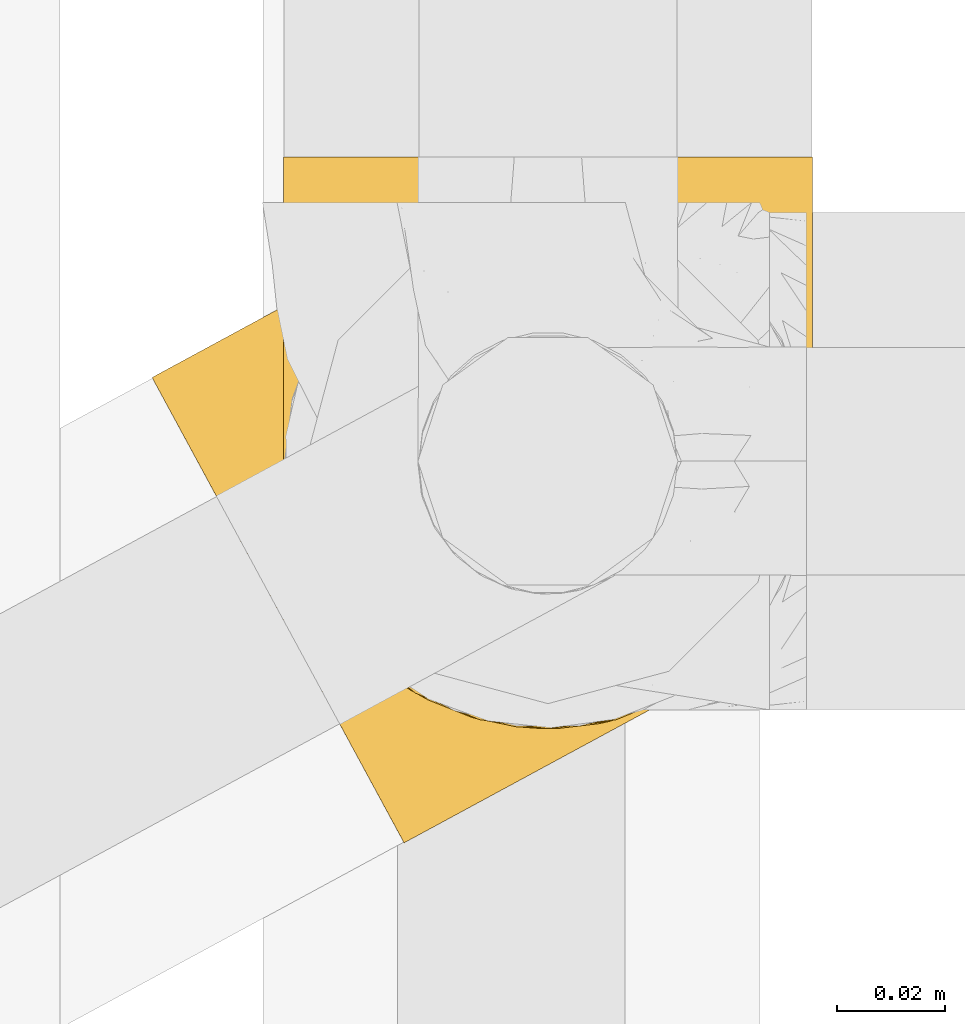
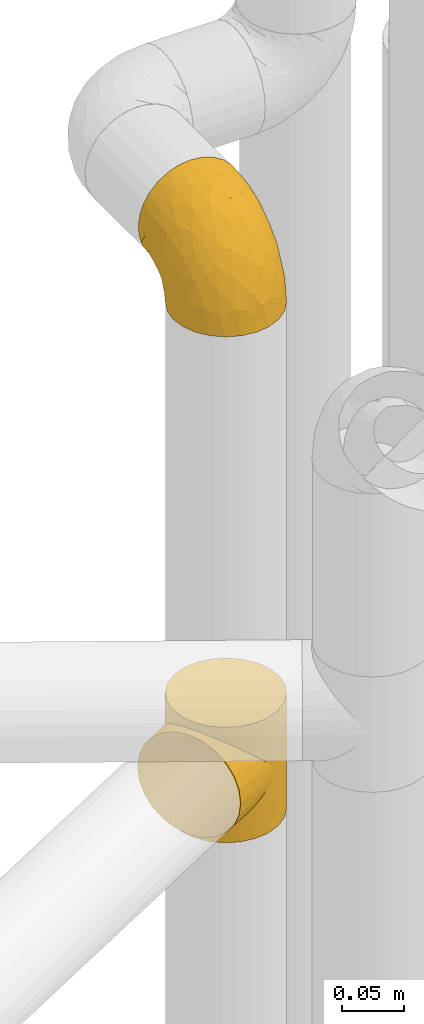
# One storey, part 159 of 827: 2 coverings.
"""IFC2X3 building model written with IfcOpenShell, lengths in millimetres."""

import ifcopenshell
import ifcopenshell.guid

model = None  # the IFC model being written
_history = None  # IfcOwnerHistory: only IFC2X3 demands one
_inside = {}  # id of a spatial element -> (the spatial element, [elements in it])
_under = {}  # id of a project, library or spatial element -> (it, [spatial elements below it])
_declared = {}  # id of a project -> (the project, [libraries it declares])
_typed = {}  # id of a type object -> (the type object, [elements of that type])
_made_of = {}  # id of a material, layer set ... -> (it, [elements and type objects made of it])


def new_model(schema):
    """Start an empty IFC model of exactly this schema.

    Asked for "IFC4X3", IfcOpenShell would pick the latest addendum, in which some entities
    have other attributes; the version numbers below select the first issue.
    IFC2X3 requires an IfcOwnerHistory on every rooted entity: one is made here for all.
    """
    global model, _history
    if schema == "IFC4X3":
        model = ifcopenshell.file(schema_version=(4, 3, 0, 0))
    else:
        model = ifcopenshell.file(schema=schema)
    _inside.clear()
    _under.clear()
    _declared.clear()
    _typed.clear()
    _made_of.clear()
    _history = None
    if model.schema == "IFC2X3":
        org = make("IfcOrganization", Name="unknown")
        user = make(
            "IfcPersonAndOrganization",
            ThePerson=make("IfcPerson", FamilyName="unknown"),
            TheOrganization=org,
        )
        app = make(
            "IfcApplication",
            ApplicationDeveloper=org,
            Version="unknown",
            ApplicationFullName="unknown",
            ApplicationIdentifier="unknown",
        )
        _history = make(
            "IfcOwnerHistory",
            OwningUser=user,
            OwningApplication=app,
            ChangeAction="ADDED",
            CreationDate=0,
        )
    return model


def make(cls, **values):
    """One entity of the class cls with the attributes given. An attribute that is None is left unset."""
    return model.create_entity(
        cls, **{name: value for name, value in values.items() if value is not None}
    )


def entity(cls, *values):
    """Any entity or typed value of the class cls, its attributes in the order of the schema. None: left unset."""
    e = model.create_entity(cls)
    for i, value in enumerate(values):
        if value is not None:
            e[i] = value
    return e


def rooted(cls, **values):
    """An entity with a GlobalId (a new one), such as an element, a storey or a relation."""
    return make(cls, GlobalId=ifcopenshell.guid.new(), OwnerHistory=_history, **values)


def si_unit(unit_type, name, prefix=None):
    """IfcSIUnit, for example si_unit("LENGTHUNIT", "METRE", prefix="MILLI")."""
    return make("IfcSIUnit", UnitType=unit_type, Prefix=prefix, Name=name)


def converted_unit(unit_type, name, factor, base, dimensions=None, offset=None):
    """IfcConversionBasedUnit, such as the inch: factor (a typed value) times the base unit."""
    return make(
        "IfcConversionBasedUnit"
        if offset is None
        else "IfcConversionBasedUnitWithOffset",
        ConversionOffset=offset,
        Dimensions=None
        if dimensions is None
        else entity("IfcDimensionalExponents", *dimensions),
        UnitType=unit_type,
        Name=name,
        ConversionFactor=make(
            "IfcMeasureWithUnit", ValueComponent=factor, UnitComponent=base
        ),
    )


def derived_unit(unit_type, elements):
    """IfcDerivedUnit: a product of units, each with its exponent."""
    return make(
        "IfcDerivedUnit",
        Elements=[
            make("IfcDerivedUnitElement", Unit=unit, Exponent=power)
            for unit, power in elements
        ],
        UnitType=unit_type,
    )


def assignment(units):
    """IfcUnitAssignment: the units of a project."""
    return None if units is None else make("IfcUnitAssignment", Units=units)


def point(xyz):
    """IfcCartesianPoint."""
    return None if xyz is None else make("IfcCartesianPoint", Coordinates=xyz)


def direction(xyz):
    """IfcDirection."""
    return None if xyz is None else make("IfcDirection", DirectionRatios=xyz)


def frame(location, z_axis=None, x_axis=None):
    """IfcAxis2Placement3D, a coordinate frame: its origin and axes. An axis left out is left unset."""
    return make(
        "IfcAxis2Placement3D",
        Location=point(location),
        Axis=direction(z_axis),
        RefDirection=direction(x_axis),
    )


def origin():
    """The frame at (0, 0, 0) with its axes left unset."""
    return frame((0.0, 0.0, 0.0))


def place(relative_to, where):
    """IfcLocalPlacement: puts the frame where relative to a parent placement (None: the world)."""
    return make(
        "IfcLocalPlacement", PlacementRelTo=relative_to, RelativePlacement=where
    )


def context(
    kind, dimensions, precision=None, world=None, true_north=None, identifier=None
):
    """IfcGeometricRepresentationContext, for example the 3D "Model" context."""
    return make(
        "IfcGeometricRepresentationContext",
        ContextIdentifier=identifier,
        ContextType=kind,
        CoordinateSpaceDimension=dimensions,
        Precision=precision,
        WorldCoordinateSystem=world,
        TrueNorth=true_north,
    )


def subcontext(parent, identifier, kind, view, scale=None):
    """IfcGeometricRepresentationSubContext, for example "Body" below "Model"."""
    return make(
        "IfcGeometricRepresentationSubContext",
        ContextIdentifier=identifier,
        ContextType=kind,
        ParentContext=parent,
        TargetScale=scale,
        TargetView=view,
    )


def project(units=None, contexts=None):
    """IfcProject with its units and contexts."""
    return rooted(
        "IfcProject",
        Name="project",
        RepresentationContexts=contexts,
        UnitsInContext=assignment(units),
    )


def spatial(cls, under=None, at=None, **own):
    """A site, building, storey or space (cls), placed at a placement, below another one or the project."""
    s = rooted(cls, ObjectPlacement=at, **own)
    if under is not None:
        _under.setdefault(under.id(), (under, []))[1].append(s)
    return s


def faces_of(points, faces, orient=None, outer=None):
    """IfcFace entities. A face is a list of loops; a loop is a list of indices into points, from 0.

    orient and outer hold one flag for each loop. By default every Orientation is true, the
    first loop of a face is its IfcFaceOuterBound and the others are IfcFaceBound.
    """
    made = []
    for i, loops in enumerate(faces):
        bounds = []
        for j, loop in enumerate(loops):
            is_outer = j == 0 if outer is None else outer[i][j]
            bounds.append(
                make(
                    "IfcFaceOuterBound" if is_outer else "IfcFaceBound",
                    Bound=make("IfcPolyLoop", Polygon=[points[k] for k in loop]),
                    Orientation=True if orient is None else orient[i][j],
                )
            )
        made.append(make("IfcFace", Bounds=bounds))
    return made


def faceted_brep(points, faces, orient=None, outer=None, voids=None):
    """IfcFacetedBrep: a solid bounded by flat faces; with voids (closed shells), ...WithVoids."""
    shared = [point(p) for p in points]
    hull = make("IfcClosedShell", CfsFaces=faces_of(shared, faces, orient, outer))
    if voids is None:
        return make("IfcFacetedBrep", Outer=hull)
    return make(
        "IfcFacetedBrepWithVoids",
        Outer=hull,
        Voids=[
            make(cls, CfsFaces=faces_of(shared, fs, o, b)) for cls, fs, o, b in voids
        ],
    )


def shape(context_of_items, identifier, shape_type, items):
    """IfcShapeRepresentation: the items that make up one representation, for example the "Body"."""
    return make(
        "IfcShapeRepresentation",
        ContextOfItems=context_of_items,
        RepresentationIdentifier=identifier,
        RepresentationType=shape_type,
        Items=items,
    )


def made_of(thing, what):
    """Note that an element or type object is made of a material, layer set ...; save() writes the relation."""
    if what is not None:
        _made_of.setdefault(what.id(), (what, []))[1].append(thing)
    return thing


def element(
    cls,
    number,
    at=None,
    inside=None,
    cuts=None,
    type_object=None,
    material=None,
    context=None,
    identifier="Body",
    shape_type=None,
    held_by="IfcProductDefinitionShape",
    body=None,
    shapes=None,
    **own,
):
    """One element of the class cls, such as IfcWall. Its Tag is "e" and its number.

    at: its placement. inside: the storey or other place that contains it. cuts: it is an
    opening in that element (IfcRelVoidsElement). A single representation is given by context,
    identifier, shape_type and body (its items); several are given by shapes. held_by: the class
    of the entity that holds the representations. save() writes the other relations.
    """
    e = rooted(cls, Tag="e%d" % number, ObjectPlacement=at, **own)
    if body is not None:
        shapes = [shape(context, identifier, shape_type, body)]
    if shapes is not None:
        e.Representation = make(held_by, Representations=shapes)
    if inside is not None:
        _inside.setdefault(inside.id(), (inside, []))[1].append(e)
    if cuts is not None:
        rooted(
            "IfcRelVoidsElement", RelatingBuildingElement=cuts, RelatedOpeningElement=e
        )
    if type_object is not None:
        _typed.setdefault(type_object.id(), (type_object, []))[1].append(e)
    return made_of(e, material)


def aggregate(whole, parts):
    """IfcRelAggregates: a whole, such as a stair, and the parts it consists of."""
    return rooted("IfcRelAggregates", RelatingObject=whole, RelatedObjects=parts)


def save(model, path):
    """Write the relations noted so far, then the file.

    IfcRelAggregates (storeys below a building ...), IfcRelContainedInSpatialStructure (elements
    in a storey), IfcRelDefinesByType, IfcRelAssociatesMaterial and IfcRelDeclares: one each for
    every whole, place, type object, material and project.
    """
    for whole, parts in _under.values():
        aggregate(whole, parts)
    for where, things in _inside.values():
        rooted(
            "IfcRelContainedInSpatialStructure",
            RelatedElements=things,
            RelatingStructure=where,
        )
    for kind, things in _typed.values():
        rooted("IfcRelDefinesByType", RelatedObjects=things, RelatingType=kind)
    for what, things in _made_of.values():
        rooted("IfcRelAssociatesMaterial", RelatedObjects=things, RelatingMaterial=what)
    for by, libraries in _declared.values():
        rooted("IfcRelDeclares", RelatingContext=by, RelatedDefinitions=libraries)
    model.write(path)


model = new_model("IFC2X3")

# Units and contexts
model_context = context("Model", 3, precision=0.01, world=origin(), true_north=direction((6.12303176911189e-17, 1.0)))
body_context = subcontext(model_context, "Body", "Model", "MODEL_VIEW")
ifc_project = project(units=[si_unit("LENGTHUNIT", "METRE", prefix="MILLI"), si_unit("AREAUNIT", "SQUARE_METRE"), si_unit("VOLUMEUNIT", "CUBIC_METRE"), converted_unit("PLANEANGLEUNIT", "DEGREE", entity("IfcRatioMeasure", 0.0174532925199433), si_unit("PLANEANGLEUNIT", "RADIAN"), dimensions=[0, 0, 0, 0, 0, 0, 0]), si_unit("MASSUNIT", "GRAM", prefix="KILO"), derived_unit("MASSDENSITYUNIT", [(si_unit("MASSUNIT", "GRAM", prefix="KILO"), 1), (si_unit("LENGTHUNIT", "METRE"), -3)]), derived_unit("MOMENTOFINERTIAUNIT", [(si_unit("LENGTHUNIT", "METRE"), 4)]), si_unit("TIMEUNIT", "SECOND"), si_unit("FREQUENCYUNIT", "HERTZ"), si_unit("THERMODYNAMICTEMPERATUREUNIT", "DEGREE_CELSIUS"), derived_unit("THERMALTRANSMITTANCEUNIT", [(si_unit("MASSUNIT", "GRAM", prefix="KILO"), 1), (si_unit("THERMODYNAMICTEMPERATUREUNIT", "KELVIN"), -1), (si_unit("TIMEUNIT", "SECOND"), -3)]), derived_unit("VOLUMETRICFLOWRATEUNIT", [(si_unit("LENGTHUNIT", "METRE"), 3), (si_unit("TIMEUNIT", "SECOND"), -1)]), derived_unit("MASSFLOWRATEUNIT", [(si_unit("MASSUNIT", "GRAM", prefix="KILO"), 1), (si_unit("TIMEUNIT", "SECOND"), -1)]), derived_unit("ROTATIONALFREQUENCYUNIT", [(si_unit("TIMEUNIT", "SECOND"), -1)]), si_unit("ELECTRICCURRENTUNIT", "AMPERE"), si_unit("ELECTRICVOLTAGEUNIT", "VOLT"), si_unit("POWERUNIT", "WATT"), si_unit("FORCEUNIT", "NEWTON", prefix="KILO"), si_unit("ILLUMINANCEUNIT", "LUX"), si_unit("LUMINOUSFLUXUNIT", "LUMEN"), si_unit("LUMINOUSINTENSITYUNIT", "CANDELA"), derived_unit("USERDEFINED", [(si_unit("MASSUNIT", "GRAM", prefix="KILO"), -1), (si_unit("LENGTHUNIT", "METRE"), -2), (si_unit("TIMEUNIT", "SECOND"), 3), (si_unit("LUMINOUSFLUXUNIT", "LUMEN"), 1)]), derived_unit("LINEARVELOCITYUNIT", [(si_unit("LENGTHUNIT", "METRE"), 1), (si_unit("TIMEUNIT", "SECOND"), -1)]), si_unit("PRESSUREUNIT", "PASCAL"), derived_unit("USERDEFINED", [(si_unit("LENGTHUNIT", "METRE"), -2), (si_unit("MASSUNIT", "GRAM", prefix="KILO"), 1), (si_unit("TIMEUNIT", "SECOND"), -2)]), derived_unit("LINEARFORCEUNIT", [(si_unit("MASSUNIT", "GRAM", prefix="KILO"), 1), (si_unit("LENGTHUNIT", "METRE"), 1), (si_unit("TIMEUNIT", "SECOND"), -2), (si_unit("LENGTHUNIT", "METRE"), -1)]), derived_unit("PLANARFORCEUNIT", [(si_unit("MASSUNIT", "GRAM", prefix="KILO"), 1), (si_unit("LENGTHUNIT", "METRE"), 1), (si_unit("TIMEUNIT", "SECOND"), -2), (si_unit("LENGTHUNIT", "METRE"), -2)])], contexts=[model_context])

# Site, building, storey
site_placement = place(None, origin())
site = spatial("IfcSite", under=ifc_project, at=site_placement, CompositionType="ELEMENT")
building_placement = place(site_placement, origin())
building = spatial("IfcBuilding", under=site, at=building_placement, CompositionType="ELEMENT")
storey_placement = place(building_placement, frame((0.0, 0.0, 28200.0)))
storey = spatial("IfcBuildingStorey", under=building, at=storey_placement, Name="08", CompositionType="ELEMENT", Elevation=28200.0)

# Coverings
covering_1_placement = place(storey_placement, frame((35661.73, 11733.71, 2043.0)))
element("IfcCovering", 1, at=covering_1_placement, inside=storey, Name=":ADSK_", ObjectType=":ADSK_", PredefinedType="INSULATION", context=body_context, shape_type="Brep", body=[
    faceted_brep([(46.11, 111.63, 50.38), (51.72, 115.18, 0.0), (41.33, 107.65, 0.0), (33.24, 97.68, 0.0), (36.42, 102.26, 37.4), (29.35, 89.87, 25.28), (28.01, 85.97, 0.0), (32.5, 96.44, 31.18), (51.72, 115.18, 57.0), (46.11, 111.63, 63.62), (51.72, 115.18, 114.0), (30.08, 52.85, 8.29), (29.61, 54.55, 0.0), (30.76, 51.55, 0.0), (40.99, 107.32, 43.83), (31.9, 48.55, 7.85), (31.9, 48.55, 0.0), (30.76, 51.55, 114.0), (31.9, 48.55, 106.15), (31.9, 48.55, 114.0), (27.13, 82.55, 19.84), (25.99, 73.3, 0.0), (26.65, 66.92, 0.0), (27.32, 60.54, 0.0), (27.3, 61.56, 10.0), (28.26, 57.15, 8.74), (26.04, 74.54, 15.07), (26.34, 65.98, 11.25), (28.46, 57.54, 0.0), (33.78, 45.96, 0.0), (35.67, 43.36, 0.0), (34.83, 44.29, 8.4), (37.76, 40.02, 8.94), (37.55, 40.76, 0.0), (39.43, 38.16, 0.0), (44.97, 33.14, 12.0), (44.41, 34.12, 0.0), (49.39, 30.08, 0.0), (41.37, 36.58, 10.47), (52.88, 28.13, 16.57), (55.25, 27.46, 0.0), (61.03, 24.87, 22.18), (48.92, 30.64, 14.29), (33.37, 46.42, 8.12), (61.11, 24.85, 0.0), (69.13, 23.17, 28.5), (73.78, 22.83, 0.0), (77.03, 22.84, 35.29), (86.54, 24.15, 0.0), (91.8, 25.72, 49.65), (98.53, 28.74, 0.0), (33.37, 46.42, 105.88), (84.61, 23.73, 42.38), (98.53, 28.74, 57.0), (91.8, 25.72, 64.35), (98.53, 28.74, 114.0), (124.25, 70.62, 114.0), (122.93, 83.38, 114.0), (118.34, 95.36, 114.0), (110.81, 105.75, 114.0), (100.85, 113.84, 114.0), (89.13, 119.07, 114.0), (76.46, 121.09, 114.0), (63.7, 119.76, 114.0), (41.33, 107.65, 114.0), (33.24, 97.68, 114.0), (28.01, 85.97, 114.0), (25.99, 73.3, 114.0), (26.65, 66.92, 114.0), (27.32, 60.54, 114.0), (28.46, 57.54, 114.0), (29.61, 54.55, 114.0), (33.78, 45.96, 114.0), (35.67, 43.36, 114.0), (37.55, 40.76, 114.0), (39.43, 38.16, 114.0), (44.41, 34.12, 114.0), (49.39, 30.08, 114.0), (55.25, 27.46, 114.0), (61.11, 24.85, 114.0), (73.78, 22.83, 114.0), (86.54, 24.15, 114.0), (108.92, 36.27, 114.0), (117.0, 46.23, 114.0), (122.23, 57.95, 114.0), (63.7, 119.76, 0.0), (76.46, 121.09, 0.0), (89.13, 119.07, 0.0), (100.85, 113.84, 0.0), (110.81, 105.75, 0.0), (118.34, 95.36, 0.0), (122.93, 83.38, 0.0), (124.25, 70.62, 0.0), (122.23, 57.95, 0.0), (117.0, 46.23, 0.0), (108.92, 36.27, 0.0), (40.99, 107.32, 70.17), (36.42, 102.26, 76.6), (30.08, 52.85, 105.71), (32.5, 96.44, 82.82), (29.35, 89.87, 88.72), (28.26, 57.15, 105.26), (27.13, 82.55, 94.16), (26.04, 74.54, 98.93), (27.3, 61.56, 104.0), (26.34, 65.98, 102.75), (44.97, 33.14, 102.0), (41.37, 36.58, 103.53), (52.88, 28.13, 97.43), (37.76, 40.02, 105.06), (61.03, 24.87, 91.82), (48.92, 30.64, 99.71), (34.83, 44.29, 105.6), (77.03, 22.84, 78.71), (84.61, 23.73, 71.62), (69.13, 23.17, 85.5), (2.39, 86.56, 44.28), (4.73, 82.24, 32.42), (8.45, 75.38, 22.25), (13.3, 66.43, 14.43), (16.12, 61.21, 11.98), (18.94, 56.0, 9.52), (20.46, 53.2, 9.11), (21.97, 50.41, 8.69), (23.48, 47.61, 8.27), (25.0, 44.82, 7.85), (26.51, 42.02, 8.27), (28.03, 39.22, 8.69), (29.54, 36.43, 9.11), (31.06, 33.63, 9.52), (33.88, 28.42, 11.98), (36.7, 23.21, 14.43), (39.12, 18.73, 18.34), (41.55, 14.25, 22.25), (45.27, 7.39, 32.42), (47.61, 3.07, 44.28), (48.4, 1.6, 57.0), (47.61, 3.07, 69.72), (45.27, 7.39, 81.57), (41.55, 14.25, 91.75), (39.12, 18.73, 95.66), (36.7, 23.21, 99.57), (33.88, 28.42, 102.02), (31.06, 33.63, 104.48), (29.54, 36.43, 104.89), (28.03, 39.22, 105.31), (26.51, 42.02, 105.73), (25.0, 44.82, 106.15), (23.48, 47.61, 105.73), (21.97, 50.41, 105.31), (20.46, 53.2, 104.89), (18.94, 56.0, 104.48), (16.12, 61.21, 102.02), (13.3, 66.43, 99.57), (8.45, 75.38, 91.75), (4.73, 82.24, 81.57), (2.39, 86.56, 69.72), (1.6, 88.04, 57.0)], [[[0, 1, 2]], [[2, 3, 4]], [[5, 3, 6]], [[5, 7, 3]], [[0, 8, 1]], [[8, 9, 10]], [[11, 12, 13]], [[4, 14, 2]], [[7, 4, 3]], [[0, 2, 14]], [[15, 13, 16]], [[17, 18, 19]], [[20, 6, 21]], [[22, 23, 24]], [[15, 11, 13]], [[23, 25, 24]], [[26, 20, 21]], [[27, 21, 22]], [[27, 22, 24]], [[25, 12, 11]], [[25, 23, 28, 12]], [[26, 21, 27]], [[6, 20, 5]], [[29, 30, 31]], [[32, 30, 33, 34]], [[35, 36, 37]], [[38, 36, 35]], [[38, 32, 34]], [[39, 37, 40]], [[41, 39, 40]], [[35, 37, 39, 42]], [[43, 16, 29]], [[40, 44, 41]], [[45, 44, 46]], [[47, 46, 48]], [[49, 48, 50]], [[47, 45, 46]], [[16, 43, 15]], [[51, 19, 18]], [[49, 52, 48]], [[53, 49, 50]], [[54, 53, 55]], [[30, 32, 31]], [[47, 48, 52]], [[36, 38, 34]], [[44, 45, 41]], [[29, 31, 43]], [[56, 57, 58, 59, 60, 61, 62, 63, 10, 64, 65, 66, 67, 68, 69, 70, 71, 17, 19, 72, 73, 74, 75, 76, 77, 78, 79, 80, 81, 55, 82, 83, 84]], [[85, 86, 87, 88, 89, 90, 91, 92, 93, 94, 95, 50, 48, 46, 44, 40, 37, 36, 34, 33, 30, 29, 16, 13, 12, 28, 23, 22, 21, 6, 3, 2, 1]], [[88, 87, 61, 60]], [[58, 90, 89, 59]], [[89, 88, 60, 59]], [[62, 86, 85, 63]], [[1, 8, 10, 63, 85]], [[61, 87, 86, 62]], [[96, 97, 64]], [[18, 17, 98]], [[9, 96, 64]], [[10, 9, 64]], [[65, 99, 100]], [[65, 64, 97]], [[71, 101, 98]], [[65, 100, 66]], [[99, 65, 97]], [[102, 103, 67]], [[104, 68, 105]], [[104, 101, 69]], [[68, 104, 69]], [[103, 105, 67]], [[66, 102, 67]], [[101, 71, 70, 69]], [[68, 67, 105]], [[98, 17, 71]], [[102, 66, 100]], [[106, 76, 107]], [[106, 77, 76]], [[77, 108, 78]], [[109, 75, 74, 73]], [[110, 78, 108]], [[111, 108, 77, 106]], [[19, 51, 72]], [[109, 73, 112]], [[72, 51, 112]], [[76, 75, 107]], [[110, 79, 78]], [[75, 109, 107]], [[113, 114, 81]], [[114, 54, 81]], [[79, 115, 80]], [[115, 79, 110]], [[113, 80, 115]], [[113, 81, 80]], [[54, 55, 81]], [[112, 73, 72]], [[53, 50, 95, 82, 55]], [[82, 95, 94, 83]], [[94, 93, 84, 83]], [[84, 93, 92, 56]], [[56, 92, 91, 57]], [[57, 91, 90, 58]], [[116, 117, 118, 119, 120, 121, 122, 123, 124, 125, 126, 127, 128, 129, 130, 131, 132, 133, 134, 135, 136, 137, 138, 139, 140, 141, 142, 143, 144, 145, 146, 147, 148, 149, 150, 151, 152, 153, 154, 155, 156, 157]], [[25, 123, 122, 121]], [[119, 118, 20]], [[15, 124, 11]], [[27, 120, 119]], [[124, 15, 125]], [[124, 123, 11]], [[120, 24, 121]], [[26, 27, 119]], [[20, 26, 119]], [[24, 120, 27]], [[25, 121, 24]], [[118, 5, 20]], [[7, 5, 117]], [[117, 5, 118]], [[4, 117, 116]], [[0, 116, 157]], [[4, 7, 117]], [[0, 14, 116]], [[8, 0, 157]], [[4, 116, 14]], [[123, 25, 11]], [[9, 157, 156]], [[156, 155, 97]], [[100, 155, 154]], [[100, 99, 155]], [[9, 8, 157]], [[98, 149, 148]], [[97, 96, 156]], [[99, 97, 155]], [[9, 156, 96]], [[18, 148, 147]], [[102, 154, 153]], [[152, 151, 104]], [[18, 98, 148]], [[151, 101, 104]], [[103, 102, 153]], [[105, 153, 152]], [[105, 152, 104]], [[101, 149, 98]], [[101, 151, 150, 149]], [[103, 153, 105]], [[154, 102, 100]], [[146, 145, 112]], [[109, 145, 144, 143]], [[106, 142, 141]], [[107, 142, 106]], [[107, 109, 143]], [[108, 141, 140]], [[110, 108, 140]], [[106, 141, 108, 111]], [[51, 147, 146]], [[140, 139, 110]], [[115, 139, 138]], [[113, 138, 137]], [[54, 137, 136]], [[113, 115, 138]], [[147, 51, 18]], [[54, 114, 137]], [[53, 54, 136]], [[145, 109, 112]], [[113, 137, 114]], [[142, 107, 143]], [[139, 115, 110]], [[146, 112, 51]], [[49, 136, 135]], [[135, 134, 47]], [[45, 134, 133]], [[45, 47, 134]], [[43, 125, 15]], [[49, 53, 136]], [[32, 129, 128, 127]], [[47, 52, 135]], [[49, 135, 52]], [[31, 127, 126]], [[131, 35, 42, 39]], [[125, 43, 126]], [[39, 132, 131]], [[130, 129, 38]], [[43, 31, 126]], [[41, 133, 132]], [[41, 132, 39]], [[35, 130, 38]], [[32, 127, 31]], [[35, 131, 130]], [[129, 32, 38]], [[133, 41, 45]]]),
])
covering_2_placement = place(storey_placement, frame((35686.11, 11754.92, 2541.4)))
element("IfcCovering", 2, at=covering_2_placement, inside=storey, Name=":ADSK_", ObjectType=":ADSK_", PredefinedType="INSULATION", context=body_context, shape_type="Brep", body=[
    faceted_brep([(1.6, 107.75, 58.6), (2.83, 107.75, 69.54), (6.47, 107.75, 79.93), (12.32, 107.75, 89.25), (20.11, 107.75, 97.03), (29.43, 107.75, 102.88), (39.81, 107.75, 106.51), (50.75, 107.75, 107.75), (61.69, 107.75, 106.51), (72.08, 107.75, 102.87), (81.4, 107.75, 97.02), (89.18, 107.75, 89.23), (95.03, 107.75, 79.91), (98.66, 107.75, 69.53), (99.9, 107.75, 58.6), (99.25, 107.75, 52.89), (98.66, 107.75, 47.65), (96.84, 107.75, 42.46), (95.02, 107.75, 37.26), (89.17, 107.75, 27.94), (81.38, 107.75, 20.16), (72.06, 107.75, 14.31), (61.68, 107.75, 10.68), (50.75, 107.75, 9.45), (39.8, 107.75, 10.68), (29.41, 107.75, 14.32), (20.09, 107.75, 20.17), (12.31, 107.75, 27.96), (6.46, 107.75, 37.28), (4.64, 107.75, 42.47), (2.83, 107.75, 47.66), (2.24, 107.75, 52.89), (1.92, 107.75, 55.75), (63.47, 98.22, 1.6), (75.32, 93.31, 1.6), (80.41, 89.4, 1.6), (85.5, 85.5, 1.6), (89.4, 80.41, 1.6), (93.31, 75.32, 1.6), (95.77, 69.39, 1.6), (98.22, 63.47, 1.6), (99.14, 56.48, 1.6), (99.52, 53.61, 1.6), (99.9, 50.75, 1.6), (98.22, 38.02, 1.6), (93.31, 26.17, 1.6), (85.5, 15.99, 1.6), (75.32, 8.18, 1.6), (63.47, 3.27, 1.6), (50.75, 1.6, 1.6), (38.02, 3.27, 1.6), (26.17, 8.18, 1.6), (15.99, 15.99, 1.6), (8.18, 26.17, 1.6), (3.27, 38.02, 1.6), (1.6, 50.75, 1.6), (2.35, 56.48, 1.6), (3.27, 63.47, 1.6), (5.73, 69.39, 1.6), (8.18, 75.32, 1.6), (12.09, 80.41, 1.6), (15.99, 85.5, 1.6), (21.08, 89.4, 1.6), (26.17, 93.31, 1.6), (38.02, 98.22, 1.6), (50.75, 99.9, 1.6), (42.18, 27.53, 69.96), (28.42, 25.32, 59.59), (37.78, 16.29, 51.96), (50.75, 6.79, 34.4), (42.85, 4.51, 23.37), (50.75, 3.51, 13.68), (24.75, 17.47, 41.52), (33.81, 7.6, 26.26), (22.57, 12.27, 20.18), (7.18, 70.89, 72.33), (2.73, 87.17, 65.88), (3.09, 67.3, 57.55), (6.92, 31.65, 23.76), (11.58, 33.58, 46.5), (5.17, 47.23, 46.57), (2.71, 43.26, 21.17), (1.6, 55.08, 23.41), (1.6, 53.99, 17.92), (1.6, 52.9, 12.43), (1.6, 52.36, 9.72), (1.6, 51.82, 7.01), (14.18, 21.5, 26.77), (5.88, 89.94, 76.59), (41.06, 60.45, 95.55), (36.25, 83.0, 102.57), (28.62, 64.79, 92.89), (1.6, 85.93, 54.26), (1.6, 81.31, 51.17), (1.6, 76.69, 48.08), (1.6, 72.06, 44.99), (1.6, 67.44, 41.9), (10.85, 88.74, 85.16), (38.35, 45.98, 85.97), (9.6, 47.13, 59.58), (26.24, 89.4, 99.5), (50.75, 95.66, 105.83), (19.31, 28.5, 53.59), (16.41, 42.81, 67.0), (24.56, 38.28, 71.56), (50.75, 45.35, 87.47), (50.75, 33.61, 75.73), (18.47, 82.57, 92.24), (1.6, 105.04, 58.06), (1.6, 102.33, 57.52), (1.6, 96.91, 56.44), (1.6, 91.42, 55.35), (14.36, 65.92, 81.33), (20.64, 53.11, 80.35), (2.32, 54.37, 39.44), (50.75, 74.94, 102.55), (1.6, 64.35, 37.28), (1.6, 61.26, 32.65), (1.6, 58.17, 28.03), (50.75, 21.87, 63.99), (33.88, 34.79, 74.55), (29.24, 48.48, 83.62), (50.75, 60.15, 95.01), (50.75, 14.33, 49.19), (2.8, 99.07, 46.96), (2.48, 60.55, 8.77), (2.7, 64.18, 18.28), (3.2, 64.36, 11.68), (32.98, 103.17, 11.79), (24.67, 101.69, 15.69), (2.95, 87.75, 42.49), (2.19, 89.38, 47.41), (17.92, 88.34, 7.94), (12.02, 82.14, 9.27), (25.73, 94.51, 7.98), (16.63, 89.64, 13.4), (25.6, 98.41, 13.04), (36.72, 99.71, 7.36), (10.66, 89.37, 23.46), (6.87, 88.21, 30.46), (11.12, 95.2, 26.54), (10.31, 79.14, 6.76), (12.84, 101.22, 26.46), (17.38, 99.41, 20.77), (9.74, 84.72, 20.68), (4.63, 97.47, 40.26), (50.75, 102.19, 7.15), (42.52, 104.02, 9.28), (3.12, 82.66, 38.78), (17.58, 95.42, 18.27), (3.97, 78.67, 31.78), (5.94, 72.69, 12.75), (2.73, 66.46, 22.96), (6.23, 75.3, 17.55), (3.45, 72.74, 27.63), (10.84, 82.93, 15.23), (7.98, 99.27, 33.25), (7.33, 93.51, 32.43), (2.39, 67.35, 27.9), (75.76, 94.51, 7.97), (90.65, 82.94, 15.22), (83.57, 88.33, 7.93), (84.85, 89.64, 13.38), (71.05, 103.62, 13.12), (98.54, 87.74, 42.49), (99.3, 89.38, 47.4), (99.9, 81.31, 51.17), (96.86, 97.47, 40.24), (84.1, 99.41, 20.76), (99.9, 52.9, 12.43), (99.9, 51.82, 7.01), (99.9, 51.28, 4.31), (88.63, 101.21, 26.44), (90.36, 95.19, 26.52), (98.29, 64.36, 11.68), (95.55, 72.69, 12.75), (89.47, 82.13, 9.27), (95.26, 75.3, 17.55), (91.18, 79.14, 6.76), (93.49, 99.28, 33.21), (94.15, 93.51, 32.41), (99.01, 60.55, 8.77), (98.76, 66.46, 22.96), (98.85, 63.96, 18.48), (99.9, 96.91, 56.44), (98.69, 99.06, 46.95), (64.78, 99.7, 7.36), (99.9, 53.99, 17.92), (99.9, 55.08, 23.41), (62.91, 103.3, 9.85), (99.9, 102.33, 57.52), (99.9, 99.62, 56.98), (99.9, 76.69, 48.08), (98.37, 82.66, 38.78), (83.9, 95.42, 18.25), (99.9, 72.06, 44.99), (97.51, 78.68, 31.74), (94.62, 88.2, 30.45), (98.04, 72.75, 27.63), (91.73, 84.74, 20.65), (99.9, 91.42, 55.35), (99.9, 85.93, 54.26), (75.87, 98.41, 13.03), (90.83, 89.37, 23.44), (99.1, 67.35, 27.9), (99.9, 61.26, 32.65), (99.9, 58.17, 28.03), (99.9, 64.35, 37.28), (99.9, 67.44, 41.9), (99.09, 54.08, 39.74), (58.64, 4.51, 23.37), (87.31, 21.5, 26.77), (89.93, 33.43, 46.18), (82.22, 28.5, 53.54), (76.74, 17.47, 41.53), (73.12, 25.36, 59.61), (95.54, 90.18, 76.79), (98.7, 86.97, 66.11), (98.79, 43.26, 21.17), (63.71, 16.29, 51.96), (67.68, 7.6, 26.26), (78.92, 12.27, 20.18), (94.57, 31.65, 23.76), (72.88, 64.79, 92.88), (65.25, 83.0, 102.57), (60.44, 60.44, 95.54), (76.94, 38.35, 71.63), (67.61, 34.8, 74.55), (94.38, 71.54, 72.51), (59.31, 27.53, 69.96), (83.03, 82.57, 92.23), (90.66, 88.74, 85.15), (80.8, 53.19, 80.45), (72.22, 48.49, 83.65), (98.39, 67.28, 57.57), (92.31, 52.32, 63.68), (63.11, 45.94, 85.95), (75.27, 89.4, 99.49), (87.15, 65.75, 81.23), (96.03, 46.73, 47.07), (85.1, 42.82, 66.99)], [[[0, 1, 2, 3, 4, 5, 6, 7, 8, 9, 10, 11, 12, 13, 14, 15, 16, 17, 18, 19, 20, 21, 22, 23, 24, 25, 26, 27, 28, 29, 30, 31, 32]], [[33, 34, 35, 36, 37, 38, 39, 40, 41, 42, 43, 44, 45, 46, 47, 48, 49, 50, 51, 52, 53, 54, 55, 56, 57, 58, 59, 60, 61, 62, 63, 64, 65]], [[66, 67, 68]], [[69, 70, 71]], [[68, 72, 73]], [[73, 72, 74]], [[75, 76, 77]], [[78, 79, 80]], [[51, 50, 73]], [[81, 82, 83, 84, 85, 86, 55]], [[52, 87, 53]], [[74, 52, 51]], [[2, 1, 88]], [[89, 90, 91]], [[77, 92, 93, 94, 95, 96]], [[55, 54, 81]], [[78, 53, 87]], [[5, 90, 6]], [[88, 76, 75]], [[97, 3, 2]], [[89, 91, 98]], [[99, 80, 79]], [[90, 5, 100]], [[74, 87, 52]], [[100, 5, 4]], [[90, 101, 6]], [[79, 102, 103]], [[102, 67, 104]], [[105, 98, 106]], [[107, 4, 3]], [[76, 0, 108, 109, 110, 111, 92]], [[107, 112, 113]], [[114, 77, 96]], [[89, 115, 90]], [[114, 96, 116, 117, 118, 82]], [[75, 97, 88]], [[119, 66, 68]], [[50, 71, 70]], [[100, 91, 90]], [[99, 77, 80]], [[102, 104, 103]], [[97, 107, 3]], [[80, 81, 78]], [[107, 97, 112]], [[68, 73, 70]], [[66, 98, 120]], [[78, 81, 54]], [[114, 81, 80]], [[53, 78, 54]], [[78, 87, 79]], [[102, 87, 72]], [[79, 103, 99]], [[4, 107, 100]], [[91, 100, 107]], [[88, 97, 2]], [[112, 97, 75]], [[99, 112, 75]], [[103, 104, 113]], [[91, 121, 98]], [[89, 105, 122, 115]], [[101, 90, 115]], [[101, 7, 6]], [[88, 1, 76]], [[0, 76, 1]], [[92, 77, 76]], [[73, 74, 51]], [[87, 74, 72]], [[81, 114, 82]], [[77, 114, 80]], [[87, 102, 79]], [[67, 102, 72]], [[68, 67, 72]], [[67, 120, 104]], [[120, 121, 104]], [[104, 121, 113]], [[121, 120, 98]], [[91, 107, 113]], [[91, 113, 121]], [[103, 113, 112]], [[106, 98, 66]], [[105, 89, 98]], [[106, 66, 119]], [[67, 66, 120]], [[68, 69, 123, 119]], [[50, 49, 71]], [[50, 70, 73]], [[112, 99, 103]], [[77, 99, 75]], [[69, 68, 70]], [[29, 124, 110]], [[84, 83, 125]], [[126, 82, 118]], [[59, 58, 127]], [[25, 128, 129]], [[130, 93, 131]], [[132, 62, 133]], [[134, 135, 136]], [[137, 65, 64]], [[64, 134, 137]], [[138, 139, 140]], [[111, 110, 124, 92]], [[134, 136, 137]], [[134, 64, 63]], [[141, 61, 60]], [[125, 58, 57]], [[142, 143, 140]], [[142, 26, 143]], [[127, 83, 82]], [[28, 124, 29]], [[108, 0, 32, 31, 30, 110, 109]], [[30, 29, 110]], [[135, 144, 138]], [[28, 145, 124]], [[57, 56, 55, 86, 85, 84]], [[146, 147, 23]], [[24, 23, 147]], [[25, 143, 26]], [[95, 94, 148]], [[24, 128, 25]], [[149, 138, 143]], [[124, 145, 131]], [[127, 58, 125]], [[150, 148, 139]], [[127, 126, 151]], [[151, 59, 127]], [[152, 151, 126]], [[153, 154, 155]], [[153, 133, 141]], [[145, 28, 27]], [[142, 156, 27]], [[157, 148, 130]], [[61, 133, 62]], [[134, 132, 135]], [[147, 128, 24]], [[65, 137, 146]], [[146, 137, 147]], [[128, 137, 136]], [[137, 128, 147]], [[128, 136, 129]], [[149, 129, 136]], [[25, 129, 143]], [[158, 152, 117]], [[152, 118, 117]], [[153, 151, 152]], [[158, 116, 154]], [[144, 150, 138]], [[153, 152, 158]], [[133, 153, 155]], [[133, 155, 132]], [[141, 60, 151]], [[135, 132, 155]], [[134, 63, 132]], [[144, 135, 155]], [[135, 138, 149]], [[155, 154, 144]], [[150, 154, 96]], [[154, 150, 144]], [[148, 94, 130]], [[82, 126, 127]], [[118, 152, 126]], [[150, 96, 95]], [[139, 148, 157]], [[150, 95, 148]], [[93, 92, 131]], [[130, 145, 156]], [[130, 94, 93]], [[84, 125, 57]], [[127, 125, 83]], [[140, 139, 157]], [[150, 139, 138]], [[140, 157, 142]], [[138, 140, 143]], [[156, 142, 157]], [[27, 26, 142]], [[130, 156, 157]], [[145, 27, 156]], [[132, 63, 62]], [[124, 131, 92]], [[130, 131, 145]], [[129, 149, 143]], [[135, 149, 136]], [[153, 141, 151]], [[59, 151, 60]], [[133, 61, 141]], [[116, 96, 154]], [[153, 158, 154]], [[158, 117, 116]], [[34, 33, 159]], [[160, 161, 162]], [[22, 21, 163]], [[164, 165, 166]], [[19, 18, 167]], [[168, 21, 20]], [[42, 41, 40, 169, 170, 171, 43]], [[172, 173, 168]], [[174, 38, 175]], [[176, 177, 178]], [[179, 164, 180]], [[40, 181, 169]], [[182, 183, 175]], [[17, 184, 185]], [[65, 146, 186]], [[187, 174, 188]], [[23, 22, 189]], [[174, 39, 38]], [[15, 14, 190, 191, 184, 16]], [[181, 40, 39]], [[192, 193, 164]], [[194, 163, 168]], [[33, 186, 159]], [[180, 173, 172]], [[195, 196, 193]], [[18, 185, 167]], [[173, 180, 197]], [[198, 199, 196]], [[200, 201, 185, 184]], [[184, 17, 16]], [[18, 17, 185]], [[202, 159, 186]], [[194, 168, 203]], [[189, 163, 202]], [[204, 205, 182]], [[187, 181, 174]], [[160, 177, 176]], [[206, 183, 182]], [[206, 182, 205]], [[201, 165, 185]], [[165, 164, 167]], [[172, 179, 180]], [[202, 194, 162]], [[176, 161, 160]], [[65, 186, 33]], [[163, 189, 22]], [[175, 177, 182]], [[174, 183, 188]], [[177, 198, 204]], [[199, 160, 162]], [[198, 207, 204]], [[175, 38, 37]], [[198, 177, 160]], [[178, 177, 175]], [[176, 35, 161]], [[34, 159, 161]], [[162, 161, 159]], [[202, 162, 159]], [[199, 162, 203]], [[196, 199, 203]], [[198, 160, 199]], [[193, 197, 180]], [[208, 198, 196]], [[188, 183, 206]], [[175, 183, 174]], [[193, 192, 195]], [[195, 208, 196]], [[197, 196, 203]], [[180, 164, 193]], [[168, 163, 21]], [[166, 165, 201]], [[166, 192, 164]], [[189, 202, 186]], [[186, 146, 189]], [[23, 189, 146]], [[174, 181, 39]], [[169, 181, 187]], [[196, 197, 193]], [[173, 203, 168]], [[203, 173, 197]], [[172, 168, 20]], [[20, 19, 172]], [[179, 172, 19]], [[19, 167, 179]], [[164, 179, 167]], [[35, 176, 36]], [[35, 34, 161]], [[185, 165, 167]], [[162, 194, 203]], [[163, 194, 202]], [[176, 178, 36]], [[37, 36, 178]], [[175, 37, 178]], [[177, 204, 182]], [[207, 198, 208]], [[207, 205, 204]], [[209, 188, 206, 205, 207, 208]], [[48, 210, 71]], [[211, 212, 213]], [[214, 213, 215]], [[216, 217, 13]], [[218, 43, 171, 170, 169, 187, 188]], [[219, 220, 214]], [[47, 46, 221]], [[210, 48, 220]], [[211, 222, 212]], [[222, 45, 44]], [[221, 220, 47]], [[47, 220, 48]], [[221, 211, 214]], [[223, 224, 225]], [[211, 46, 45]], [[226, 227, 215]], [[43, 218, 44]], [[217, 216, 228]], [[219, 215, 229]], [[14, 13, 217]], [[224, 9, 8]], [[10, 230, 11]], [[11, 231, 12]], [[232, 223, 233]], [[234, 208, 195, 192, 166, 201]], [[235, 234, 228]], [[222, 44, 218]], [[106, 229, 236]], [[224, 237, 9]], [[231, 238, 228]], [[9, 237, 10]], [[115, 224, 101]], [[239, 234, 235]], [[231, 11, 230]], [[223, 230, 237]], [[224, 8, 101]], [[223, 236, 233]], [[225, 115, 122, 105]], [[216, 12, 231]], [[209, 234, 239]], [[210, 219, 69]], [[219, 214, 215]], [[229, 119, 219]], [[209, 218, 188]], [[239, 212, 222]], [[239, 222, 218]], [[45, 222, 211]], [[235, 212, 239]], [[213, 212, 240]], [[223, 237, 224]], [[230, 10, 237]], [[238, 231, 230]], [[216, 231, 228]], [[232, 230, 223]], [[235, 238, 240]], [[115, 225, 224]], [[233, 236, 227]], [[8, 7, 101]], [[234, 209, 208]], [[218, 209, 239]], [[217, 228, 234]], [[13, 12, 216]], [[234, 201, 217]], [[217, 201, 200, 184, 191, 190, 14]], [[211, 221, 46]], [[220, 221, 214]], [[71, 210, 69]], [[71, 49, 48]], [[219, 210, 220]], [[226, 215, 213]], [[211, 213, 214]], [[226, 213, 240]], [[215, 227, 229]], [[232, 240, 238]], [[233, 227, 226]], [[232, 233, 226]], [[236, 223, 225]], [[240, 232, 226]], [[232, 238, 230]], [[225, 105, 236]], [[236, 105, 106]], [[236, 229, 227]], [[123, 69, 219, 119]], [[106, 119, 229]], [[238, 235, 228]], [[212, 235, 240]]]),
])

save(model, "model.ifc")
